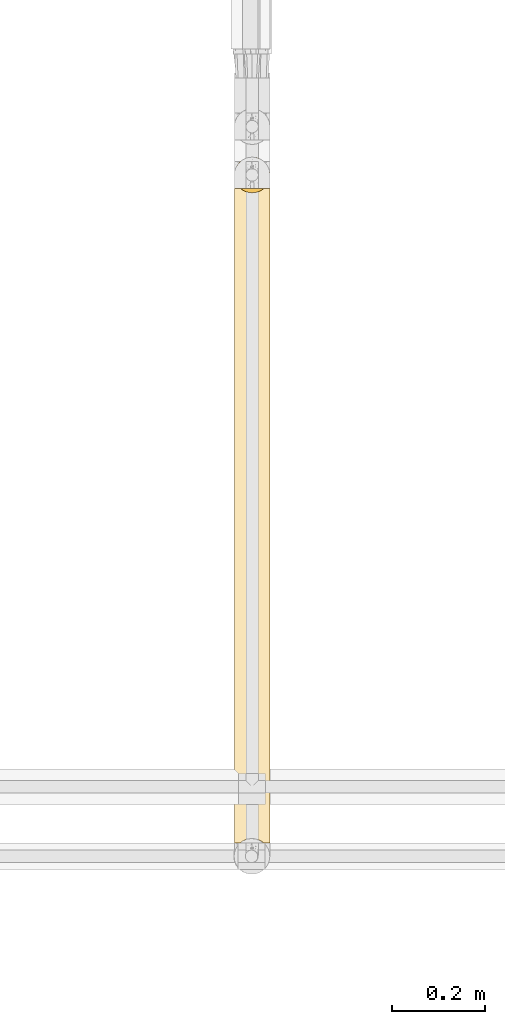
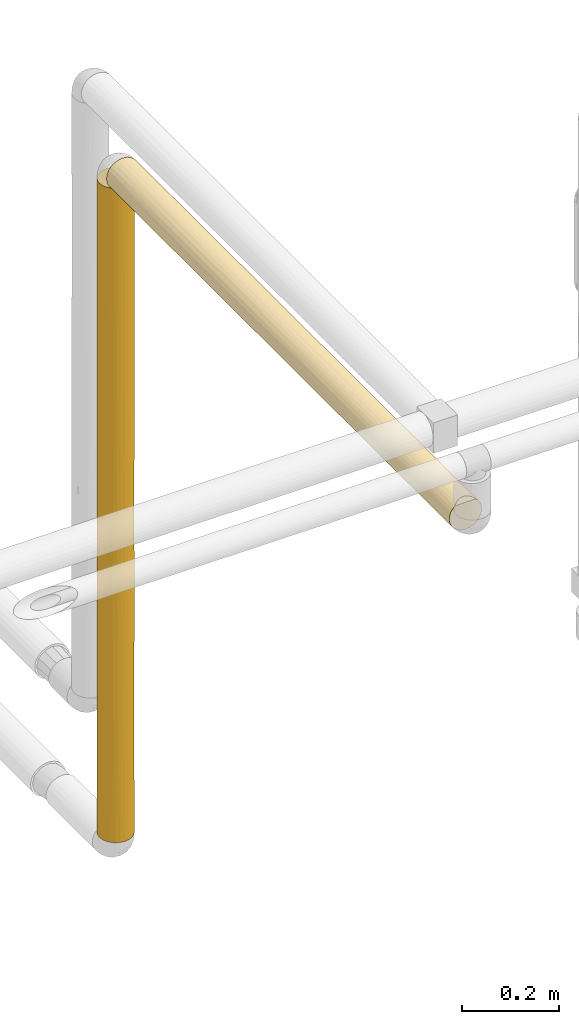
# One storey, part 24 of 827: 2 coverings.
"""IFC2X3 building model written with IfcOpenShell, lengths in millimetres."""

from ifc_helpers import new_model, entity, si_unit, converted_unit, derived_unit, direction, frame, origin, place, context, subcontext, project, spatial, faceted_brep, element, save


model = new_model("IFC2X3")

# Units and contexts
model_context = context("Model", 3, precision=0.01, world=origin(), true_north=direction((6.12303176911189e-17, 1.0)))
body_context = subcontext(model_context, "Body", "Model", "MODEL_VIEW")
ifc_project = project(units=[si_unit("LENGTHUNIT", "METRE", prefix="MILLI"), si_unit("AREAUNIT", "SQUARE_METRE"), si_unit("VOLUMEUNIT", "CUBIC_METRE"), converted_unit("PLANEANGLEUNIT", "DEGREE", entity("IfcRatioMeasure", 0.0174532925199433), si_unit("PLANEANGLEUNIT", "RADIAN"), dimensions=[0, 0, 0, 0, 0, 0, 0]), si_unit("MASSUNIT", "GRAM", prefix="KILO"), derived_unit("MASSDENSITYUNIT", [(si_unit("MASSUNIT", "GRAM", prefix="KILO"), 1), (si_unit("LENGTHUNIT", "METRE"), -3)]), derived_unit("MOMENTOFINERTIAUNIT", [(si_unit("LENGTHUNIT", "METRE"), 4)]), si_unit("TIMEUNIT", "SECOND"), si_unit("FREQUENCYUNIT", "HERTZ"), si_unit("THERMODYNAMICTEMPERATUREUNIT", "DEGREE_CELSIUS"), derived_unit("THERMALTRANSMITTANCEUNIT", [(si_unit("MASSUNIT", "GRAM", prefix="KILO"), 1), (si_unit("THERMODYNAMICTEMPERATUREUNIT", "KELVIN"), -1), (si_unit("TIMEUNIT", "SECOND"), -3)]), derived_unit("VOLUMETRICFLOWRATEUNIT", [(si_unit("LENGTHUNIT", "METRE"), 3), (si_unit("TIMEUNIT", "SECOND"), -1)]), derived_unit("MASSFLOWRATEUNIT", [(si_unit("MASSUNIT", "GRAM", prefix="KILO"), 1), (si_unit("TIMEUNIT", "SECOND"), -1)]), derived_unit("ROTATIONALFREQUENCYUNIT", [(si_unit("TIMEUNIT", "SECOND"), -1)]), si_unit("ELECTRICCURRENTUNIT", "AMPERE"), si_unit("ELECTRICVOLTAGEUNIT", "VOLT"), si_unit("POWERUNIT", "WATT"), si_unit("FORCEUNIT", "NEWTON", prefix="KILO"), si_unit("ILLUMINANCEUNIT", "LUX"), si_unit("LUMINOUSFLUXUNIT", "LUMEN"), si_unit("LUMINOUSINTENSITYUNIT", "CANDELA"), derived_unit("USERDEFINED", [(si_unit("MASSUNIT", "GRAM", prefix="KILO"), -1), (si_unit("LENGTHUNIT", "METRE"), -2), (si_unit("TIMEUNIT", "SECOND"), 3), (si_unit("LUMINOUSFLUXUNIT", "LUMEN"), 1)]), derived_unit("LINEARVELOCITYUNIT", [(si_unit("LENGTHUNIT", "METRE"), 1), (si_unit("TIMEUNIT", "SECOND"), -1)]), si_unit("PRESSUREUNIT", "PASCAL"), derived_unit("USERDEFINED", [(si_unit("LENGTHUNIT", "METRE"), -2), (si_unit("MASSUNIT", "GRAM", prefix="KILO"), 1), (si_unit("TIMEUNIT", "SECOND"), -2)]), derived_unit("LINEARFORCEUNIT", [(si_unit("MASSUNIT", "GRAM", prefix="KILO"), 1), (si_unit("LENGTHUNIT", "METRE"), 1), (si_unit("TIMEUNIT", "SECOND"), -2), (si_unit("LENGTHUNIT", "METRE"), -1)]), derived_unit("PLANARFORCEUNIT", [(si_unit("MASSUNIT", "GRAM", prefix="KILO"), 1), (si_unit("LENGTHUNIT", "METRE"), 1), (si_unit("TIMEUNIT", "SECOND"), -2), (si_unit("LENGTHUNIT", "METRE"), -2)])], contexts=[model_context])

# Site, building, storey
site_placement = place(None, origin())
site = spatial("IfcSite", under=ifc_project, at=site_placement, CompositionType="ELEMENT")
building_placement = place(site_placement, origin())
building = spatial("IfcBuilding", under=site, at=building_placement, CompositionType="ELEMENT")
storey_placement = place(building_placement, frame((0.0, 0.0, 28200.0)))
storey = spatial("IfcBuildingStorey", under=building, at=storey_placement, Name="08", CompositionType="ELEMENT", Elevation=28200.0)

# Coverings
covering_1_placement = place(storey_placement, frame((13238.8, 11020.39, 1027.51)))
element("IfcCovering", 1, at=covering_1_placement, inside=storey, Name=":ADSK_", ObjectType=":ADSK_", PredefinedType="INSULATION", context=body_context, shape_type="Brep", body=[
    faceted_brep([(77.51, 31.79, 1643.39), (78.4, 40.0, 1643.39), (77.09, 49.93, 1643.39), (73.25, 59.2, 1643.39), (67.15, 67.15, 1643.39), (59.2, 73.25, 1643.39), (49.93, 77.09, 1643.39), (40.0, 78.4, 1643.39), (30.06, 77.09, 1643.39), (20.8, 73.25, 1643.39), (12.84, 67.15, 1643.39), (6.74, 59.2, 1643.39), (2.9, 49.93, 1643.39), (1.6, 40.0, 1643.39), (2.48, 31.79, 1643.39), (5.09, 23.98, 1643.39), (9.31, 16.91, 1643.39), (14.94, 10.9, 1643.39), (65.05, 10.9, 1643.39), (70.68, 16.91, 1643.39), (74.9, 23.98, 1643.39), (77.09, 30.06, 1.6), (73.25, 20.8, 1.6), (67.15, 12.84, 1.6), (59.2, 6.74, 1.6), (49.93, 2.9, 1.6), (40.0, 1.6, 1.6), (30.06, 2.9, 1.6), (20.8, 6.74, 1.6), (12.84, 12.84, 1.6), (6.74, 20.8, 1.6), (2.9, 30.06, 1.6), (1.6, 40.0, 1.6), (2.48, 48.2, 1.6), (5.09, 56.01, 1.6), (9.31, 63.08, 1.6), (14.94, 69.1, 1.6), (65.05, 69.1, 1.6), (70.68, 63.08, 1.6), (74.9, 56.01, 1.6), (77.51, 48.2, 1.6), (78.4, 40.0, 1.6), (72.98, 59.66, 218.66), (70.46, 63.37, 1139.31), (70.46, 63.37, 1412.16), (75.47, 54.69, 1328.91), (54.69, 75.47, 1419.48), (76.41, 52.17, 287.23), (78.4, 40.0, 217.97), (77.14, 49.74, 616.82), (78.4, 40.0, 434.34), (63.37, 70.46, 1333.94), (64.53, 69.54, 995.65), (68.03, 66.24, 287.24), (48.24, 77.5, 335.45), (50.46, 76.94, 688.07), (56.68, 74.58, 384.99), (56.77, 74.54, 892.92), (57.11, 74.37, 606.06), (74.15, 57.54, 1090.16), (76.73, 51.18, 1144.27), (77.75, 47.03, 1318.83), (53.36, 76.0, 8.5), (46.78, 77.79, 10.29), (72.98, 59.66, 485.18), (40.0, 78.4, 227.27), (54.69, 75.47, 1152.8), (48.4, 77.46, 972.26), (47.44, 77.67, 1343.45), (67.73, 66.56, 544.14), (62.48, 71.13, 194.06), (40.0, 78.4, 1259.89), (40.0, 78.4, 1427.02), (40.0, 78.4, 1068.14), (63.21, 70.58, 406.86), (71.06, 62.56, 805.19), (62.77, 70.91, 717.19), (78.4, 40.0, 1427.02), (40.0, 78.4, 443.64), (59.51, 73.07, 5.57), (40.0, 78.4, 10.9), (40.0, 78.4, 876.39), (78.4, 40.0, 1210.64), (78.4, 40.0, 867.09), (76.08, 53.13, 939.0), (78.4, 40.0, 777.9), (78.4, 40.0, 650.71), (74.84, 56.14, 731.92), (40.0, 78.4, 660.01), (78.4, 40.0, 994.28), (31.75, 77.5, 335.45), (29.53, 76.94, 688.07), (16.78, 70.58, 406.86), (17.51, 71.13, 194.06), (11.96, 66.24, 287.24), (7.01, 59.66, 218.66), (16.62, 70.46, 1333.94), (20.48, 73.07, 5.57), (26.63, 76.0, 8.5), (33.21, 77.79, 10.29), (1.6, 40.0, 1210.64), (2.25, 47.03, 1318.83), (3.26, 51.18, 1144.27), (7.01, 59.66, 485.18), (3.58, 52.17, 287.23), (23.31, 74.58, 384.99), (25.3, 75.47, 1152.8), (15.46, 69.54, 995.65), (9.53, 63.37, 1412.16), (4.52, 54.69, 1328.91), (25.3, 75.47, 1419.48), (32.55, 77.67, 1343.45), (12.26, 66.56, 544.14), (8.93, 62.56, 805.19), (9.53, 63.37, 1139.31), (1.6, 40.0, 867.09), (1.6, 40.0, 994.27), (31.59, 77.46, 972.26), (2.85, 49.74, 616.82), (3.91, 53.13, 939.0), (1.6, 40.0, 434.34), (1.6, 40.0, 217.97), (22.88, 74.37, 606.06), (23.22, 74.54, 892.92), (5.84, 57.54, 1090.16), (1.6, 40.0, 1427.02), (1.6, 40.0, 650.71), (1.6, 40.0, 777.9), (5.43, 56.72, 691.06), (17.22, 70.91, 717.19), (9.53, 16.62, 232.82), (4.52, 25.3, 316.07), (16.78, 9.41, 1238.13), (11.96, 13.75, 1357.74), (12.26, 13.43, 1100.84), (25.3, 4.52, 225.5), (32.55, 2.32, 301.53), (25.3, 4.52, 492.18), (31.59, 2.53, 672.72), (16.62, 9.53, 311.04), (31.75, 2.49, 1309.53), (26.63, 4.0, 1636.49), (23.31, 5.41, 1259.99), (3.58, 27.82, 1357.75), (7.01, 20.33, 1159.8), (2.25, 32.96, 326.15), (7.01, 20.33, 1426.33), (3.26, 28.81, 500.71), (8.93, 17.43, 839.79), (9.53, 16.62, 505.67), (15.46, 10.45, 649.34), (40.0, 1.6, 768.6), (29.53, 3.05, 956.92), (33.21, 2.2, 1634.69), (40.0, 1.6, 1417.71), (40.0, 1.6, 1634.09), (17.51, 8.86, 1450.92), (40.0, 1.6, 217.97), (40.0, 1.6, 1201.34), (20.48, 6.92, 1639.42), (2.85, 30.25, 1028.17), (3.91, 26.86, 705.99), (22.88, 5.62, 1038.93), (23.22, 5.45, 752.07), (5.84, 22.45, 554.82), (40.0, 1.6, 385.1), (40.0, 1.6, 576.84), (5.43, 23.27, 953.92), (40.0, 1.6, 984.97), (17.22, 9.08, 927.8), (63.37, 9.53, 311.04), (77.75, 32.96, 326.15), (54.69, 4.52, 492.18), (48.4, 2.53, 672.72), (47.44, 2.32, 301.53), (64.53, 10.45, 649.34), (71.06, 17.43, 839.79), (62.77, 9.08, 927.8), (70.46, 16.62, 505.67), (70.46, 16.62, 232.82), (75.47, 25.3, 316.07), (62.48, 8.86, 1450.92), (56.68, 5.41, 1259.99), (63.21, 9.41, 1238.13), (54.69, 4.52, 225.5), (53.36, 4.0, 1636.49), (48.24, 2.49, 1309.53), (46.78, 2.2, 1634.69), (68.03, 13.75, 1357.74), (72.98, 20.33, 1426.33), (72.98, 20.33, 1159.8), (76.41, 27.82, 1357.75), (50.46, 3.05, 956.92), (59.51, 6.92, 1639.42), (56.77, 5.45, 752.07), (57.11, 5.62, 1038.93), (67.73, 13.43, 1100.84), (74.15, 22.45, 554.82), (76.73, 28.81, 500.71), (77.14, 30.25, 1028.17), (76.08, 26.86, 705.99), (74.84, 23.85, 913.06)], [[[0, 1, 2, 3, 4, 5, 6, 7, 8, 9, 10, 11, 12, 13, 14, 15, 16, 17, 18, 19, 20]], [[21, 22, 23, 24, 25, 26, 27, 28, 29, 30, 31, 32, 33, 34, 35, 36, 37, 38, 39, 40, 41]], [[42, 39, 38]], [[43, 44, 45]], [[46, 6, 5]], [[47, 48, 40]], [[49, 50, 47]], [[51, 43, 52]], [[53, 42, 38]], [[54, 55, 56]], [[57, 58, 55]], [[59, 45, 60]], [[61, 60, 45]], [[62, 63, 54]], [[42, 64, 47]], [[39, 47, 40]], [[65, 54, 63]], [[4, 3, 44]], [[66, 67, 68]], [[37, 53, 38]], [[53, 69, 64]], [[70, 62, 56]], [[71, 72, 68, 73]], [[74, 70, 56]], [[52, 75, 76]], [[51, 66, 46]], [[4, 51, 5]], [[2, 45, 3]], [[2, 1, 77]], [[65, 78, 54]], [[70, 37, 79]], [[57, 55, 67]], [[74, 76, 69]], [[49, 47, 64]], [[45, 44, 3]], [[63, 80, 65]], [[81, 67, 55]], [[54, 56, 62]], [[57, 67, 66]], [[58, 56, 55]], [[44, 51, 4]], [[57, 52, 76]], [[61, 77, 82]], [[6, 72, 7]], [[60, 83, 84]], [[49, 83, 85, 86, 50]], [[84, 87, 75]], [[87, 64, 75]], [[83, 49, 84]], [[48, 47, 50]], [[48, 41, 40]], [[51, 44, 43]], [[51, 46, 5]], [[68, 6, 46]], [[73, 68, 67]], [[6, 68, 72]], [[66, 68, 46]], [[73, 67, 81]], [[55, 78, 88, 81]], [[52, 66, 51]], [[57, 76, 58]], [[52, 57, 66]], [[75, 52, 43]], [[75, 43, 59]], [[75, 64, 69]], [[60, 82, 89, 83]], [[77, 61, 2]], [[2, 61, 45]], [[82, 60, 61]], [[59, 60, 84]], [[75, 59, 84]], [[45, 59, 43]], [[74, 69, 53]], [[75, 69, 76]], [[53, 37, 70]], [[74, 56, 58]], [[70, 79, 62]], [[53, 70, 74]], [[64, 42, 53]], [[39, 42, 47]], [[78, 55, 54]], [[74, 58, 76]], [[84, 49, 87]], [[64, 87, 49]], [[78, 90, 91]], [[92, 93, 94]], [[35, 95, 94]], [[9, 96, 10]], [[35, 94, 36]], [[97, 93, 98]], [[99, 98, 90]], [[100, 101, 102]], [[103, 94, 95]], [[104, 95, 34]], [[8, 7, 72]], [[90, 98, 105]], [[96, 106, 107]], [[11, 108, 109]], [[101, 12, 109]], [[110, 111, 106]], [[112, 94, 103]], [[113, 114, 107]], [[102, 115, 116, 100]], [[109, 12, 11]], [[104, 34, 33]], [[8, 110, 9]], [[81, 91, 117]], [[92, 94, 112]], [[10, 108, 11]], [[118, 115, 119]], [[65, 80, 99]], [[9, 110, 96]], [[117, 106, 111]], [[120, 104, 121]], [[78, 65, 90]], [[93, 97, 36]], [[104, 33, 121]], [[118, 104, 120]], [[99, 90, 65]], [[90, 105, 91]], [[105, 122, 91]], [[117, 123, 106]], [[106, 123, 107]], [[108, 96, 114]], [[124, 119, 102]], [[71, 73, 111, 72]], [[12, 125, 13]], [[119, 124, 113]], [[118, 103, 104]], [[118, 120, 126, 127, 115]], [[128, 119, 113]], [[33, 32, 121]], [[96, 108, 10]], [[109, 108, 114]], [[72, 111, 8]], [[96, 110, 106]], [[117, 73, 81]], [[8, 111, 110]], [[73, 117, 111]], [[88, 78, 91, 81]], [[91, 122, 123]], [[91, 123, 117]], [[123, 129, 107]], [[129, 112, 113]], [[96, 107, 114]], [[129, 113, 107]], [[113, 103, 128]], [[12, 101, 125]], [[100, 125, 101]], [[102, 101, 109]], [[124, 109, 114]], [[102, 119, 115]], [[109, 124, 102]], [[113, 124, 114]], [[113, 112, 103]], [[129, 122, 92]], [[129, 92, 112]], [[105, 98, 93]], [[94, 93, 36]], [[105, 93, 92]], [[34, 95, 35]], [[103, 95, 104]], [[92, 122, 105]], [[123, 122, 129]], [[103, 118, 128]], [[119, 128, 118]], [[29, 130, 30]], [[30, 130, 131]], [[132, 133, 134]], [[135, 136, 137]], [[138, 137, 136]], [[28, 135, 139]], [[140, 141, 142]], [[131, 31, 30]], [[100, 143, 125]], [[134, 133, 144]], [[145, 31, 131]], [[144, 133, 146]], [[28, 27, 135]], [[120, 145, 147]], [[143, 146, 15]], [[148, 149, 150]], [[151, 152, 138]], [[153, 141, 140]], [[154, 155, 153]], [[132, 156, 133]], [[27, 26, 157]], [[16, 146, 133]], [[140, 152, 158]], [[16, 133, 17]], [[156, 141, 159]], [[28, 139, 29]], [[160, 127, 161]], [[150, 139, 137]], [[147, 127, 126, 120]], [[143, 15, 14]], [[158, 154, 140]], [[156, 159, 17]], [[143, 14, 125]], [[160, 143, 100]], [[153, 140, 154]], [[140, 142, 152]], [[142, 162, 152]], [[138, 163, 137]], [[137, 163, 150]], [[130, 139, 149]], [[164, 161, 147]], [[165, 166, 136, 157]], [[31, 121, 32]], [[161, 164, 148]], [[160, 144, 143]], [[160, 100, 116, 115, 127]], [[167, 161, 148]], [[14, 13, 125]], [[139, 130, 29]], [[131, 130, 149]], [[157, 136, 27]], [[139, 135, 137]], [[138, 166, 151]], [[27, 136, 135]], [[166, 138, 136]], [[168, 158, 152, 151]], [[152, 162, 163]], [[152, 163, 138]], [[163, 169, 150]], [[169, 134, 148]], [[139, 150, 149]], [[169, 148, 150]], [[148, 144, 167]], [[31, 145, 121]], [[120, 121, 145]], [[147, 145, 131]], [[164, 131, 149]], [[147, 161, 127]], [[131, 164, 147]], [[148, 164, 149]], [[148, 134, 144]], [[169, 162, 132]], [[169, 132, 134]], [[142, 141, 156]], [[133, 156, 17]], [[142, 156, 132]], [[15, 146, 16]], [[144, 146, 143]], [[132, 162, 142]], [[163, 162, 169]], [[144, 160, 167]], [[161, 167, 160]], [[24, 23, 170]], [[50, 171, 48]], [[172, 173, 174]], [[175, 176, 177]], [[178, 179, 180]], [[181, 182, 183]], [[170, 172, 184]], [[185, 182, 181]], [[23, 22, 179]], [[154, 186, 187]], [[184, 25, 24]], [[18, 188, 19]], [[189, 190, 191]], [[191, 77, 0]], [[186, 192, 182]], [[165, 157, 174, 166]], [[181, 18, 193]], [[194, 195, 192]], [[194, 192, 173]], [[188, 189, 19]], [[188, 196, 190]], [[170, 178, 175]], [[20, 191, 0]], [[197, 180, 198]], [[189, 20, 19]], [[199, 82, 191]], [[185, 187, 186]], [[154, 158, 186]], [[21, 180, 22]], [[180, 171, 198]], [[183, 177, 196]], [[199, 191, 190]], [[0, 77, 1]], [[187, 155, 154]], [[151, 173, 192]], [[186, 182, 185]], [[194, 173, 172]], [[195, 182, 192]], [[179, 170, 23]], [[194, 175, 177]], [[21, 48, 171]], [[25, 157, 26]], [[198, 85, 200]], [[199, 85, 83, 89, 82]], [[200, 201, 176]], [[201, 190, 176]], [[85, 199, 200]], [[180, 179, 22]], [[82, 77, 191]], [[170, 179, 178]], [[170, 184, 24]], [[174, 25, 184]], [[166, 174, 173]], [[25, 174, 157]], [[172, 174, 184]], [[166, 173, 151]], [[192, 158, 168, 151]], [[175, 172, 170]], [[194, 177, 195]], [[175, 194, 172]], [[176, 175, 178]], [[176, 178, 197]], [[176, 190, 196]], [[21, 41, 48]], [[198, 50, 86, 85]], [[21, 171, 180]], [[50, 198, 171]], [[197, 198, 200]], [[176, 197, 200]], [[180, 197, 178]], [[183, 196, 188]], [[176, 196, 177]], [[188, 18, 181]], [[183, 182, 195]], [[181, 193, 185]], [[188, 181, 183]], [[190, 189, 188]], [[20, 189, 191]], [[158, 192, 186]], [[183, 195, 177]], [[200, 199, 201]], [[190, 201, 199]], [[159, 141, 153, 155, 187, 185, 193, 18, 17]], [[97, 98, 99, 80, 63, 62, 79, 37, 36]]]),
])
covering_2_placement = place(storey_placement, frame((13238.8, 9620.3, 2660.0)))
element("IfcCovering", 2, at=covering_2_placement, inside=storey, Name=":ADSK_", ObjectType=":ADSK_", PredefinedType="INSULATION", context=body_context, shape_type="Brep", body=[
    faceted_brep([(20.8, 1410.98, 73.25), (30.06, 1410.98, 77.09), (40.0, 1410.98, 78.4), (49.93, 1410.98, 77.09), (59.2, 1410.98, 73.25), (67.15, 1410.98, 67.15), (73.25, 1410.98, 59.2), (77.09, 1410.98, 49.93), (78.4, 1410.98, 40.0), (77.51, 1410.98, 31.79), (74.9, 1410.98, 23.98), (70.68, 1410.98, 16.91), (65.05, 1410.98, 10.9), (14.94, 1410.98, 10.9), (9.31, 1410.98, 16.91), (5.09, 1410.98, 23.98), (2.48, 1410.98, 31.79), (1.6, 1410.98, 40.0), (2.9, 1410.98, 49.93), (6.74, 1410.98, 59.2), (12.84, 1410.98, 67.15), (14.66, 1.6, 68.85), (9.14, 1.6, 62.86), (5.01, 1.6, 55.84), (2.46, 1.6, 48.11), (1.6, 1.6, 40.0), (2.9, 1.6, 30.06), (6.74, 1.6, 20.8), (12.84, 1.6, 12.84), (20.8, 1.6, 6.74), (30.06, 1.6, 2.9), (40.0, 1.6, 1.6), (49.93, 1.6, 2.9), (59.2, 1.6, 6.74), (67.15, 1.6, 12.84), (73.25, 1.6, 20.8), (77.09, 1.6, 30.06), (78.4, 1.6, 40.0), (77.49, 1.6, 48.29), (74.82, 1.6, 56.18), (70.51, 1.6, 63.31), (64.76, 1.6, 69.34), (75.47, 190.11, 25.3), (77.61, 308.98, 32.27), (63.2, 1006.42, 9.4), (62.48, 1218.89, 8.86), (68.03, 1126.35, 13.75), (70.46, 288.56, 16.62), (75.47, 427.85, 25.3), (57.18, 593.1, 5.65), (48.2, 507.39, 2.48), (50.61, 725.26, 3.09), (72.98, 1194.16, 20.33), (72.98, 929.88, 20.33), (67.77, 871.29, 13.48), (76.41, 1126.36, 27.82), (70.87, 618.27, 17.17), (74.53, 721.67, 23.21), (59.51, 1407.01, 6.92), (53.36, 1404.08, 4.0), (40.0, 217.97, 1.6), (40.0, 1185.31, 1.6), (40.0, 1401.68, 1.6), (46.78, 1402.29, 2.2), (40.0, 968.93, 1.6), (48.22, 1077.12, 2.49), (57.12, 812.13, 5.63), (78.4, 1194.61, 40.0), (54.69, 168.06, 4.52), (63.37, 254.75, 9.53), (77.13, 796.53, 30.23), (56.67, 1031.37, 5.41), (62.89, 478.76, 9.16), (47.82, 278.39, 2.4), (54.69, 388.72, 4.52), (78.4, 978.23, 40.0), (40.0, 536.19, 1.6), (40.0, 752.56, 1.6), (77.55, 540.83, 32.01), (78.4, 761.86, 40.0), (78.4, 650.72, 40.0), (78.4, 545.49, 40.0), (78.4, 434.34, 40.0), (78.4, 217.97, 40.0), (62.77, 703.42, 9.08), (78.4, 867.09, 40.0), (9.53, 288.56, 16.62), (16.62, 254.75, 9.53), (16.79, 1006.42, 9.4), (17.22, 703.42, 9.08), (12.22, 871.29, 13.48), (25.3, 168.06, 4.52), (32.17, 278.39, 2.4), (17.51, 1218.89, 8.86), (20.48, 1407.01, 6.92), (23.32, 1031.37, 5.41), (29.39, 725.26, 3.09), (31.77, 1077.12, 2.49), (4.52, 190.11, 25.3), (7.01, 929.88, 20.33), (11.96, 1126.35, 13.75), (26.63, 1404.08, 4.0), (3.58, 1126.36, 27.82), (1.6, 1194.61, 40.0), (33.21, 1402.29, 2.2), (4.52, 427.85, 25.3), (9.12, 618.27, 17.17), (2.38, 308.98, 32.27), (23.23, 604.39, 5.45), (31.79, 507.39, 2.48), (2.44, 540.83, 32.01), (7.01, 1194.16, 20.33), (2.86, 796.53, 30.23), (1.6, 978.23, 40.0), (22.58, 818.03, 5.77), (1.6, 545.49, 40.0), (1.6, 650.71, 40.0), (1.6, 761.86, 40.0), (25.3, 388.72, 4.52), (5.06, 658.65, 24.05), (17.65, 477.83, 8.77), (1.6, 217.97, 40.0), (1.6, 434.34, 40.0), (1.6, 867.09, 40.0), (2.84, 608.36, 49.67), (3.53, 284.72, 52.04), (17.25, 191.35, 70.93), (20.24, 5.61, 72.92), (4.52, 1222.46, 54.69), (22.07, 590.96, 73.96), (29.02, 652.08, 76.79), (23.26, 798.84, 74.56), (32.27, 1115.08, 77.61), (25.3, 1020.51, 75.47), (33.16, 885.95, 77.78), (6.89, 216.36, 59.46), (2.44, 871.74, 47.99), (2.38, 1103.59, 47.72), (11.74, 284.73, 66.0), (40.0, 227.27, 78.4), (31.65, 335.45, 77.48), (33.11, 10.34, 77.77), (4.52, 984.72, 54.69), (40.0, 443.64, 78.4), (6.89, 481.5, 59.46), (16.57, 402.56, 70.43), (16.96, 709.94, 70.72), (12.05, 539.45, 66.34), (26.46, 8.56, 75.93), (23.11, 382.22, 74.48), (9.53, 1124.02, 63.37), (40.0, 710.94, 78.4), (16.62, 1157.82, 70.46), (26.33, 1230.78, 75.88), (17.83, 934.9, 71.35), (9.13, 792.94, 62.84), (40.0, 10.89, 78.4), (40.0, 660.01, 78.4), (5.03, 750.52, 55.88), (40.0, 876.39, 78.4), (40.0, 1060.96, 78.4), (40.0, 1194.61, 78.4), (59.27, 5.52, 73.21), (62.21, 196.0, 71.32), (53.18, 8.43, 76.06), (54.69, 1027.1, 75.47), (62.99, 409.73, 70.75), (67.8, 287.74, 66.48), (70.46, 1124.02, 63.37), (63.37, 1157.82, 70.46), (72.86, 220.49, 59.86), (50.45, 687.43, 76.95), (48.1, 335.45, 77.53), (72.86, 483.92, 59.86), (46.69, 10.24, 77.81), (47.94, 1145.72, 77.56), (47.98, 909.89, 77.56), (75.47, 1222.46, 54.69), (62.59, 934.01, 71.05), (70.89, 796.2, 62.8), (56.46, 380.23, 74.69), (67.61, 543.17, 66.68), (74.48, 688.41, 56.9), (75.47, 984.72, 54.69), (77.61, 1103.59, 47.72), (76.37, 287.74, 52.31), (56.9, 598.23, 74.47), (56.84, 818.04, 74.5), (77.11, 623.87, 49.85), (77.55, 871.74, 47.99), (62.5, 708.44, 71.11)], [[[0, 1, 2, 3, 4, 5, 6, 7, 8, 9, 10, 11, 12, 13, 14, 15, 16, 17, 18, 19, 20]], [[21, 22, 23, 24, 25, 26, 27, 28, 29, 30, 31, 32, 33, 34, 35, 36, 37, 38, 39, 40, 41]], [[36, 42, 43]], [[44, 45, 46]], [[42, 47, 48]], [[49, 50, 51]], [[52, 53, 46]], [[44, 46, 54]], [[55, 10, 9]], [[35, 42, 36]], [[56, 57, 48]], [[58, 45, 59]], [[32, 31, 60]], [[35, 34, 47]], [[46, 11, 52]], [[61, 62, 63]], [[55, 52, 10]], [[64, 65, 51]], [[54, 46, 53]], [[63, 65, 61]], [[51, 66, 49]], [[56, 48, 47]], [[9, 8, 67]], [[32, 68, 33]], [[47, 34, 69]], [[63, 59, 65]], [[12, 11, 46]], [[53, 55, 70]], [[51, 65, 71]], [[47, 72, 56]], [[45, 58, 12]], [[68, 73, 74]], [[55, 67, 75]], [[70, 55, 75]], [[65, 59, 71]], [[64, 61, 65]], [[66, 51, 71]], [[50, 74, 73]], [[76, 77, 50]], [[34, 33, 69]], [[56, 53, 57]], [[78, 79, 80, 81]], [[78, 81, 43]], [[43, 81, 82, 83]], [[83, 37, 36]], [[72, 47, 69]], [[9, 67, 55]], [[54, 56, 84]], [[68, 69, 33]], [[74, 49, 72]], [[56, 54, 53]], [[84, 66, 44]], [[84, 44, 54]], [[71, 59, 45]], [[46, 45, 12]], [[71, 45, 44]], [[47, 42, 35]], [[43, 42, 48]], [[43, 48, 78]], [[36, 43, 83]], [[57, 78, 48]], [[78, 70, 79]], [[10, 52, 11]], [[53, 52, 55]], [[73, 32, 60]], [[69, 68, 74]], [[32, 73, 68]], [[76, 73, 60]], [[73, 76, 50]], [[77, 64, 51]], [[44, 66, 71]], [[49, 66, 84]], [[72, 49, 84]], [[49, 74, 50]], [[56, 72, 84]], [[74, 72, 69]], [[50, 77, 51]], [[70, 75, 85, 79]], [[53, 70, 57]], [[57, 70, 78]], [[28, 86, 87]], [[88, 89, 90]], [[30, 91, 92]], [[30, 60, 31]], [[93, 13, 94]], [[88, 93, 95]], [[29, 91, 30]], [[96, 95, 97]], [[98, 86, 27]], [[97, 61, 64]], [[29, 28, 87]], [[90, 99, 100]], [[95, 93, 101]], [[102, 103, 16]], [[61, 97, 104]], [[105, 106, 86]], [[107, 105, 98]], [[108, 96, 109]], [[105, 107, 110]], [[100, 111, 14]], [[13, 100, 14]], [[111, 15, 14]], [[15, 102, 16]], [[26, 98, 27]], [[112, 113, 102]], [[27, 86, 28]], [[101, 104, 97]], [[99, 102, 111]], [[114, 96, 108]], [[115, 110, 107]], [[112, 102, 99]], [[16, 103, 17]], [[104, 62, 61]], [[109, 96, 77]], [[97, 95, 101]], [[110, 115, 116, 117]], [[118, 109, 92]], [[105, 119, 106]], [[89, 108, 120]], [[99, 106, 119]], [[110, 117, 112]], [[26, 25, 121]], [[90, 106, 99]], [[60, 92, 76]], [[113, 103, 102]], [[106, 89, 120]], [[86, 106, 120]], [[91, 87, 118]], [[88, 90, 100]], [[106, 90, 89]], [[100, 13, 93]], [[88, 95, 114]], [[93, 94, 101]], [[100, 93, 88]], [[107, 26, 121]], [[86, 98, 105]], [[26, 107, 98]], [[107, 121, 122, 115]], [[110, 119, 105]], [[119, 110, 112]], [[99, 111, 100]], [[15, 111, 102]], [[87, 91, 29]], [[92, 91, 118]], [[108, 109, 118]], [[30, 92, 60]], [[96, 64, 77]], [[76, 92, 109]], [[120, 118, 87]], [[114, 108, 89]], [[118, 120, 108]], [[120, 87, 86]], [[88, 114, 89]], [[96, 114, 95]], [[64, 96, 97]], [[76, 109, 77]], [[112, 117, 123, 113]], [[99, 119, 112]], [[124, 122, 125]], [[126, 21, 127]], [[128, 19, 18]], [[129, 130, 131]], [[132, 133, 134]], [[135, 23, 22]], [[123, 136, 137]], [[22, 138, 135]], [[139, 140, 141]], [[128, 137, 142]], [[139, 143, 140]], [[21, 138, 22]], [[125, 135, 144]], [[145, 146, 147]], [[148, 149, 126]], [[128, 150, 19]], [[151, 134, 130]], [[0, 20, 152]], [[121, 24, 125]], [[138, 147, 144]], [[23, 125, 24]], [[150, 152, 20]], [[143, 130, 140]], [[153, 133, 132]], [[130, 149, 140]], [[148, 141, 140]], [[142, 137, 136]], [[149, 145, 126]], [[146, 154, 155]], [[19, 150, 20]], [[124, 125, 144]], [[121, 25, 24]], [[141, 156, 139]], [[130, 143, 157, 151]], [[140, 149, 148]], [[144, 155, 158]], [[130, 134, 131]], [[155, 150, 142]], [[146, 131, 154]], [[134, 151, 159, 160]], [[1, 132, 2]], [[136, 116, 124]], [[18, 17, 103]], [[158, 155, 142]], [[147, 155, 144]], [[150, 155, 154]], [[153, 152, 133]], [[145, 147, 138]], [[155, 147, 146]], [[138, 21, 126]], [[145, 149, 129]], [[126, 127, 148]], [[138, 126, 145]], [[137, 18, 103]], [[150, 128, 142]], [[18, 137, 128]], [[137, 103, 113, 123]], [[136, 158, 142]], [[158, 136, 124]], [[132, 134, 160]], [[131, 134, 133]], [[132, 160, 161, 2]], [[153, 132, 1]], [[1, 0, 153]], [[152, 153, 0]], [[144, 135, 138]], [[23, 135, 125]], [[125, 122, 121]], [[154, 133, 152]], [[129, 131, 146]], [[133, 154, 131]], [[154, 152, 150]], [[145, 129, 146]], [[130, 129, 149]], [[136, 123, 117, 116]], [[124, 116, 115, 122]], [[144, 158, 124]], [[162, 163, 164]], [[4, 3, 165]], [[166, 163, 167]], [[168, 5, 169]], [[167, 40, 170]], [[167, 41, 40]], [[171, 143, 172]], [[143, 139, 172]], [[173, 167, 170]], [[174, 164, 172]], [[175, 159, 176]], [[6, 177, 7]], [[168, 178, 179]], [[172, 164, 180]], [[181, 167, 173]], [[175, 2, 161, 160, 159]], [[166, 167, 181]], [[6, 5, 168]], [[179, 182, 183]], [[7, 177, 184]], [[185, 39, 38]], [[185, 170, 39]], [[171, 186, 187]], [[168, 183, 177]], [[82, 185, 83]], [[173, 185, 188]], [[139, 156, 174]], [[67, 8, 7]], [[143, 171, 157]], [[179, 183, 168]], [[163, 162, 41]], [[185, 38, 83]], [[188, 185, 82]], [[174, 172, 139]], [[172, 180, 171]], [[186, 171, 180]], [[176, 159, 151, 157]], [[5, 4, 169]], [[179, 173, 182]], [[189, 80, 79, 85]], [[189, 85, 184]], [[184, 85, 75, 67]], [[38, 37, 83]], [[178, 168, 169]], [[181, 179, 190]], [[4, 165, 169]], [[165, 187, 178]], [[168, 177, 6]], [[184, 177, 183]], [[184, 183, 189]], [[7, 184, 67]], [[182, 189, 183]], [[189, 188, 80]], [[179, 181, 173]], [[190, 186, 166]], [[190, 166, 181]], [[180, 164, 163]], [[167, 163, 41]], [[180, 163, 166]], [[39, 170, 40]], [[173, 170, 185]], [[176, 157, 171]], [[166, 186, 180]], [[187, 186, 190]], [[178, 187, 190]], [[187, 165, 176]], [[179, 178, 190]], [[165, 178, 169]], [[187, 176, 171]], [[176, 165, 175]], [[165, 3, 175]], [[2, 175, 3]], [[188, 82, 81, 80]], [[173, 188, 182]], [[182, 188, 189]], [[59, 63, 62, 104, 101, 94, 13, 12, 58]], [[164, 174, 156, 141, 148, 127, 21, 41, 162]]]),
])

save(model, "model.ifc")
